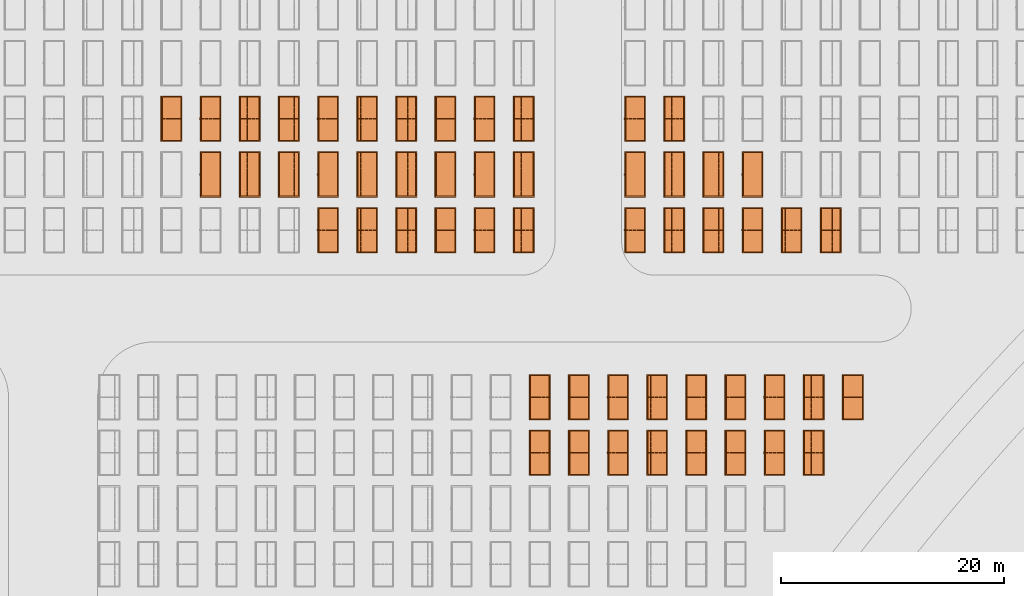
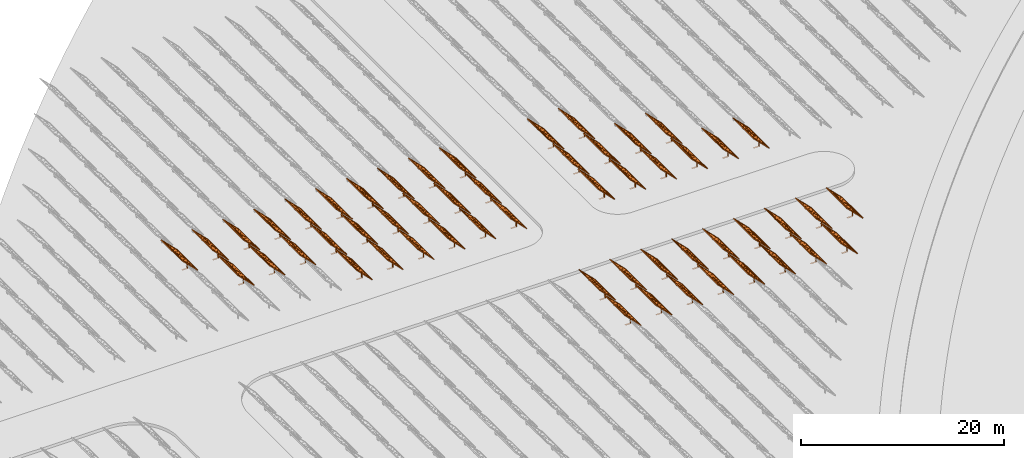
# One storey, part 34 of 39: 54 proxies.
"""IFC2X3 building model written with IfcOpenShell, lengths in millimetres."""

from ifc_helpers import new_model, entity, si_unit, converted_unit, derived_unit, direction, frame, frame_2d, origin, origin_2d_with_axis, place, context, subcontext, project, spatial, polyline, rectangle, outline, extrude, source, transform, mapped, material, material_list, element, save


model = new_model("IFC2X3")

# Units and contexts
model_context = context("Model", 3, precision=1e-06, world=origin(), true_north=direction((2.0, 6.12303176911189e-17, 1.0)))
context_of_model = context(None, 3, precision=1e-06, world=origin(), true_north=direction((2.0, 6.12303176911189e-17, 1.0)))
body_context = subcontext(model_context, "Body", "Model", "MODEL_VIEW")
ifc_project = project(units=[si_unit("LENGTHUNIT", "METRE", prefix="MILLI"), si_unit("AREAUNIT", "SQUARE_METRE", prefix="MILLI"), si_unit("VOLUMEUNIT", "CUBIC_METRE", prefix="MILLI"), converted_unit("PLANEANGLEUNIT", "DEGREE", entity("IfcRatioMeasure", 0.0174532925199433), si_unit("PLANEANGLEUNIT", "RADIAN"), dimensions=[0, 0, 0, 0, 0, 0, 0]), si_unit("MASSUNIT", "GRAM", prefix="KILO"), si_unit("TIMEUNIT", "SECOND"), si_unit("THERMODYNAMICTEMPERATUREUNIT", "KELVIN"), derived_unit("THERMALTRANSMITTANCEUNIT", [(si_unit("MASSUNIT", "GRAM", prefix="KILO"), 1), (si_unit("THERMODYNAMICTEMPERATUREUNIT", "KELVIN"), -1), (si_unit("TIMEUNIT", "SECOND"), -3)]), derived_unit("VOLUMETRICFLOWRATEUNIT", [(si_unit("LENGTHUNIT", "METRE"), 3), (si_unit("TIMEUNIT", "SECOND"), -1)])], contexts=[model_context, context_of_model])

# Site, building, storey
site_placement = place(None, origin())
site = spatial("IfcSite", under=ifc_project, at=site_placement, CompositionType="ELEMENT")
building_placement = place(site_placement, origin())
building = spatial("IfcBuilding", under=site, at=building_placement, CompositionType="ELEMENT")
storey_placement = place(building_placement, frame((0.0, 0.0, 4000.0)))
storey = spatial("IfcBuildingStorey", under=building, at=storey_placement, Name="Level 2", CompositionType="ELEMENT", Elevation=4000.0)

# Proxies
ifc_material_1 = material(Name="Stand-Steel")
ifc_material_2 = material(Name="Aluminium")
ifc_material_3 = material(Name="Glass")
ifc_material_list_1 = material_list([ifc_material_1, ifc_material_2, ifc_material_3])
shared_shape = source(origin(), body_context, "Body", "SweptSolid", [
    extrude(outline(polyline([(-629.526235435404, -220.0), (329.763117717702, -220.0), (329.763117717703, 410.0), (299.763117717703, 410.0), (299.763117717702, -190.0), (-629.526235435404, -190.0), (-629.526235435404, -220.0)])), frame((-190.00003127179, -100.0, 299.763117717707), z_axis=(0.0, 1.0, 0.0), x_axis=(0.0, 0.0, -1.0)), (0.0, 0.0, 1.0), 200.0),
    extrude(rectangle(XDim=20.0000000000001, YDim=200.0, at=frame_2d((0.0, -7.105427357601e-14), x_axis=(0.0, 1.0))), frame((-7.07109908365613, 0.0, 922.21828534124), z_axis=(-0.70710678118654, 0.0, 0.707106781186555), x_axis=(0.0, 1.0, 0.0)), (0.0, 0.0, 1.0), 2600.0),
    extrude(rectangle(XDim=24.9999999999997, YDim=24.9999999999999, at=frame_2d((2.87769807982841e-13, -9.50350909079134e-14), x_axis=(1.0, 0.0))), frame((-1449.56292018118, -1950.0, 2449.57494522722), z_axis=(0.0, 1.0, 0.0), x_axis=(-0.707106781186548, 0.0, -0.707106781186548)), (0.0, 0.0, 1.0), 3900.0),
    extrude(rectangle(XDim=24.9999999999999, YDim=25.0000000000001, at=origin_2d_with_axis()), frame((-1096.0095295879, -1950.0, 2096.02155463395), z_axis=(0.0, 1.0, 0.0), x_axis=(-0.707106781186542, 0.0, -0.707106781186553)), (0.0, 0.0, 1.0), 3900.0),
    extrude(rectangle(XDim=24.9999999999999, YDim=25.0000000000001, at=origin_2d_with_axis()), frame((-742.456138994631, -1950.0, 1742.46816404067), z_axis=(0.0, 1.0, 0.0), x_axis=(-0.707106781186542, 0.0, -0.707106781186553)), (0.0, 0.0, 1.0), 3900.0),
    extrude(rectangle(XDim=25.0, YDim=24.9999999999997, at=frame_2d((-7.19424519957101e-14, 1.19904086659517e-13), x_axis=(1.0, 0.0))), frame((-388.902748401358, -1950.0, 1388.9147734474), z_axis=(0.0, 1.0, 0.0), x_axis=(-0.707106781186545, 0.0, -0.70710678118655)), (0.0, 0.0, 1.0), 3900.0),
    extrude(rectangle(XDim=25.0000000000002, YDim=25.0, at=frame_2d((1.35891298214119e-13, 6.21724893790088e-15), x_axis=(0.0, 1.0))), frame((-35.3553703311048, 1500.0, 1035.35537033109), z_axis=(-0.707106781186544, 0.0, 0.707106781186551), x_axis=(0.0, 1.0, 0.0)), (0.0, 0.0, 1.0), 2440.0),
    extrude(rectangle(XDim=25.0000000000002, YDim=25.0, at=frame_2d((0.0, 1.77635683940025e-15), x_axis=(0.0, 1.0))), frame((-35.3553703311059, 1000.0, 1035.35537033109), z_axis=(-0.707106781186546, 0.0, 0.707106781186549), x_axis=(0.0, 1.0, 0.0)), (0.0, 0.0, 1.0), 2440.0),
    extrude(rectangle(XDim=25.0000000000002, YDim=25.0, at=frame_2d((0.0, 8.43769498715119e-14), x_axis=(0.0, 1.0))), frame((-26.5165355662756, 0.0, 1044.19420509593), z_axis=(-0.707106781186546, 0.0, 0.707106781186549), x_axis=(0.0, -1.0, 0.0)), (0.0, 0.0, 1.0), 2440.0),
    extrude(rectangle(XDim=25.0000000000002, YDim=25.0, at=frame_2d((0.0, 8.88178419700125e-16), x_axis=(0.0, 1.0))), frame((-35.3553703311065, 500.0, 1035.35537033109), z_axis=(-0.707106781186546, 0.0, 0.707106781186549), x_axis=(0.0, 1.0, 0.0)), (0.0, 0.0, 1.0), 2440.0),
    extrude(rectangle(XDim=25.0000000000002, YDim=25.0, at=frame_2d((0.0, 8.88178419700125e-16), x_axis=(0.0, 1.0))), frame((-35.3553703311086, -500.0, 1035.35537033109), z_axis=(-0.707106781186546, 0.0, 0.707106781186549), x_axis=(0.0, 1.0, 0.0)), (0.0, 0.0, 1.0), 2440.0),
    extrude(rectangle(XDim=25.0000000000002, YDim=25.0, at=frame_2d((0.0, 8.88178419700125e-16), x_axis=(0.0, 1.0))), frame((-35.3553703311095, -1000.0, 1035.35537033109), z_axis=(-0.707106781186546, 0.0, 0.707106781186549), x_axis=(0.0, 1.0, 0.0)), (0.0, 0.0, 1.0), 2440.0),
    extrude(rectangle(XDim=25.0000000000002, YDim=25.0, at=frame_2d((1.35891298214119e-13, 1.77635683940025e-15), x_axis=(0.0, 1.0))), frame((-35.3553703311107, -1500.0, 1035.35537033109), z_axis=(-0.707106781186546, 0.0, 0.707106781186549), x_axis=(0.0, 1.0, 0.0)), (0.0, 0.0, 1.0), 2440.0),
    extrude(rectangle(XDim=2400.0, YDim=11.9999999999994, at=frame_2d((-1.13686837721616e-13, 2.02948768901479e-13), x_axis=(1.0, 0.0))), frame((-883.883507754966, -1950.0, 1883.88350775495), z_axis=(0.0, 1.0, 0.0), x_axis=(0.707106781186546, 0.0, -0.707106781186549)), (0.0, 0.0, 1.0), 3900.0),
    extrude(outline(polyline([(-2050.0, -1300.0), (2050.0, -1300.0), (2050.0, 1300.0), (-2050.0, 1300.0), (-2050.0, -1300.0)]), holes=[polyline([(1950.0, -1200.0), (-1950.0, -1200.0), (-1950.0, 1200.0), (1950.0, 1200.0), (1950.0, -1200.0)])]), frame((-919.238846814293, 0.0, 1848.52816869563), z_axis=(0.707106781186554, 0.0, 0.707106781186541), x_axis=(0.0, 1.0, 0.0)), (0.0, 0.0, 1.0), 99.9999999999898),
])
proxy_1_placement = place(storey_placement, frame((-109235.224594532, 625144.680552408, 30.0)))
element("IfcBuildingElementProxy", 1, at=proxy_1_placement, inside=storey, material=ifc_material_list_1, Name="Solar Panel_4000X2500:Solar Panel_4000X2500", ObjectType="Solar Panel_4000X2500", CompositionType="ELEMENT", context=body_context, shape_type="MappedRepresentation", body=[
    mapped(shared_shape, transform((0.0, 0.0, 0.0), scale=1.0)),
])
ifc_material_list_2 = material_list([ifc_material_1, ifc_material_2, ifc_material_3])
proxy_2_placement = place(storey_placement, frame((-109235.224594532, 630144.680552408, 30.0)))
element("IfcBuildingElementProxy", 2, at=proxy_2_placement, inside=storey, material=ifc_material_list_2, Name="Solar Panel_4000X2500:Solar Panel_4000X2500", ObjectType="Solar Panel_4000X2500", CompositionType="ELEMENT", context=body_context, shape_type="MappedRepresentation", body=[
    mapped(shared_shape, transform((0.0, 0.0, 0.0), scale=1.0)),
])
ifc_material_list_3 = material_list([ifc_material_1, ifc_material_2, ifc_material_3])
proxy_3_placement = place(storey_placement, frame((-105720.214222803, 625144.680552408, 30.0)))
element("IfcBuildingElementProxy", 3, at=proxy_3_placement, inside=storey, material=ifc_material_list_3, Name="Solar Panel_4000X2500:Solar Panel_4000X2500", ObjectType="Solar Panel_4000X2500", CompositionType="ELEMENT", context=body_context, shape_type="MappedRepresentation", body=[
    mapped(shared_shape, transform((0.0, 0.0, 0.0), scale=1.0)),
])
ifc_material_list_4 = material_list([ifc_material_1, ifc_material_2, ifc_material_3])
proxy_4_placement = place(storey_placement, frame((-105720.214222803, 630144.680552408, 30.0)))
element("IfcBuildingElementProxy", 4, at=proxy_4_placement, inside=storey, material=ifc_material_list_4, Name="Solar Panel_4000X2500:Solar Panel_4000X2500", ObjectType="Solar Panel_4000X2500", CompositionType="ELEMENT", context=body_context, shape_type="MappedRepresentation", body=[
    mapped(shared_shape, transform((0.0, 0.0, 0.0), scale=1.0)),
])
ifc_material_list_5 = material_list([ifc_material_1, ifc_material_2, ifc_material_3])
proxy_5_placement = place(storey_placement, frame((-102205.203851073, 625144.680552408, 30.0)))
element("IfcBuildingElementProxy", 5, at=proxy_5_placement, inside=storey, material=ifc_material_list_5, Name="Solar Panel_4000X2500:Solar Panel_4000X2500", ObjectType="Solar Panel_4000X2500", CompositionType="ELEMENT", context=body_context, shape_type="MappedRepresentation", body=[
    mapped(shared_shape, transform((0.0, 0.0, 0.0), scale=1.0)),
])
ifc_material_list_6 = material_list([ifc_material_1, ifc_material_2, ifc_material_3])
proxy_6_placement = place(storey_placement, frame((-102205.203851073, 630144.680552408, 30.0)))
element("IfcBuildingElementProxy", 6, at=proxy_6_placement, inside=storey, material=ifc_material_list_6, Name="Solar Panel_4000X2500:Solar Panel_4000X2500", ObjectType="Solar Panel_4000X2500", CompositionType="ELEMENT", context=body_context, shape_type="MappedRepresentation", body=[
    mapped(shared_shape, transform((0.0, 0.0, 0.0), scale=1.0)),
])
ifc_material_list_7 = material_list([ifc_material_1, ifc_material_2, ifc_material_3])
proxy_7_placement = place(storey_placement, frame((-98690.193479343, 625144.680552408, 30.0)))
element("IfcBuildingElementProxy", 7, at=proxy_7_placement, inside=storey, material=ifc_material_list_7, Name="Solar Panel_4000X2500:Solar Panel_4000X2500", ObjectType="Solar Panel_4000X2500", CompositionType="ELEMENT", context=body_context, shape_type="MappedRepresentation", body=[
    mapped(shared_shape, transform((0.0, 0.0, 0.0), scale=1.0)),
])
ifc_material_list_8 = material_list([ifc_material_1, ifc_material_2, ifc_material_3])
proxy_8_placement = place(storey_placement, frame((-98690.193479343, 630144.680552408, 30.0)))
element("IfcBuildingElementProxy", 8, at=proxy_8_placement, inside=storey, material=ifc_material_list_8, Name="Solar Panel_4000X2500:Solar Panel_4000X2500", ObjectType="Solar Panel_4000X2500", CompositionType="ELEMENT", context=body_context, shape_type="MappedRepresentation", body=[
    mapped(shared_shape, transform((0.0, 0.0, 0.0), scale=1.0)),
])
ifc_material_list_9 = material_list([ifc_material_1, ifc_material_2, ifc_material_3])
proxy_9_placement = place(storey_placement, frame((-95175.1831076132, 625144.680552408, 30.0)))
element("IfcBuildingElementProxy", 9, at=proxy_9_placement, inside=storey, material=ifc_material_list_9, Name="Solar Panel_4000X2500:Solar Panel_4000X2500", ObjectType="Solar Panel_4000X2500", CompositionType="ELEMENT", context=body_context, shape_type="MappedRepresentation", body=[
    mapped(shared_shape, transform((0.0, 0.0, 0.0), scale=1.0)),
])
ifc_material_list_10 = material_list([ifc_material_1, ifc_material_2, ifc_material_3])
proxy_10_placement = place(storey_placement, frame((-95175.1831076132, 630144.680552408, 30.0)))
element("IfcBuildingElementProxy", 10, at=proxy_10_placement, inside=storey, material=ifc_material_list_10, Name="Solar Panel_4000X2500:Solar Panel_4000X2500", ObjectType="Solar Panel_4000X2500", CompositionType="ELEMENT", context=body_context, shape_type="MappedRepresentation", body=[
    mapped(shared_shape, transform((0.0, 0.0, 0.0), scale=1.0)),
])
ifc_material_list_11 = material_list([ifc_material_1, ifc_material_2, ifc_material_3])
proxy_11_placement = place(storey_placement, frame((-91660.1727358834, 625144.680552408, 30.0)))
element("IfcBuildingElementProxy", 11, at=proxy_11_placement, inside=storey, material=ifc_material_list_11, Name="Solar Panel_4000X2500:Solar Panel_4000X2500", ObjectType="Solar Panel_4000X2500", CompositionType="ELEMENT", context=body_context, shape_type="MappedRepresentation", body=[
    mapped(shared_shape, transform((0.0, 0.0, 0.0), scale=1.0)),
])
ifc_material_list_12 = material_list([ifc_material_1, ifc_material_2, ifc_material_3])
proxy_12_placement = place(storey_placement, frame((-91660.1727358834, 630144.680552408, 30.0)))
element("IfcBuildingElementProxy", 12, at=proxy_12_placement, inside=storey, material=ifc_material_list_12, Name="Solar Panel_4000X2500:Solar Panel_4000X2500", ObjectType="Solar Panel_4000X2500", CompositionType="ELEMENT", context=body_context, shape_type="MappedRepresentation", body=[
    mapped(shared_shape, transform((0.0, 0.0, 0.0), scale=1.0)),
])
ifc_material_list_13 = material_list([ifc_material_1, ifc_material_2, ifc_material_3])
proxy_13_placement = place(storey_placement, frame((-88145.1623641536, 625144.680552408, 30.0)))
element("IfcBuildingElementProxy", 13, at=proxy_13_placement, inside=storey, material=ifc_material_list_13, Name="Solar Panel_4000X2500:Solar Panel_4000X2500", ObjectType="Solar Panel_4000X2500", CompositionType="ELEMENT", context=body_context, shape_type="MappedRepresentation", body=[
    mapped(shared_shape, transform((0.0, 0.0, 0.0), scale=1.0)),
])
ifc_material_list_14 = material_list([ifc_material_1, ifc_material_2, ifc_material_3])
proxy_14_placement = place(storey_placement, frame((-88145.1623641536, 630144.680552408, 30.0)))
element("IfcBuildingElementProxy", 14, at=proxy_14_placement, inside=storey, material=ifc_material_list_14, Name="Solar Panel_4000X2500:Solar Panel_4000X2500", ObjectType="Solar Panel_4000X2500", CompositionType="ELEMENT", context=body_context, shape_type="MappedRepresentation", body=[
    mapped(shared_shape, transform((0.0, 0.0, 0.0), scale=1.0)),
])
ifc_material_list_15 = material_list([ifc_material_1, ifc_material_2, ifc_material_3])
proxy_15_placement = place(storey_placement, frame((-84630.1519924238, 625144.680552408, 30.0)))
element("IfcBuildingElementProxy", 15, at=proxy_15_placement, inside=storey, material=ifc_material_list_15, Name="Solar Panel_4000X2500:Solar Panel_4000X2500", ObjectType="Solar Panel_4000X2500", CompositionType="ELEMENT", context=body_context, shape_type="MappedRepresentation", body=[
    mapped(shared_shape, transform((0.0, 0.0, 0.0), scale=1.0)),
])
ifc_material_list_16 = material_list([ifc_material_1, ifc_material_2, ifc_material_3])
proxy_16_placement = place(storey_placement, frame((-84630.1519924238, 630144.680552408, 30.0)))
element("IfcBuildingElementProxy", 16, at=proxy_16_placement, inside=storey, material=ifc_material_list_16, Name="Solar Panel_4000X2500:Solar Panel_4000X2500", ObjectType="Solar Panel_4000X2500", CompositionType="ELEMENT", context=body_context, shape_type="MappedRepresentation", body=[
    mapped(shared_shape, transform((0.0, 0.0, 0.0), scale=1.0)),
])
ifc_material_list_17 = material_list([ifc_material_1, ifc_material_2, ifc_material_3])
proxy_17_placement = place(storey_placement, frame((-81115.141620694, 630144.680552408, 30.0)))
element("IfcBuildingElementProxy", 17, at=proxy_17_placement, inside=storey, material=ifc_material_list_17, Name="Solar Panel_4000X2500:Solar Panel_4000X2500", ObjectType="Solar Panel_4000X2500", CompositionType="ELEMENT", context=body_context, shape_type="MappedRepresentation", body=[
    mapped(shared_shape, transform((0.0, 0.0, 0.0), scale=1.0)),
])
ifc_material_list_18 = material_list([ifc_material_1, ifc_material_2, ifc_material_3])
proxy_18_placement = place(storey_placement, frame((-128250.276453181, 645144.680552408, 30.0)))
element("IfcBuildingElementProxy", 18, at=proxy_18_placement, inside=storey, material=ifc_material_list_18, Name="Solar Panel_4000X2500:Solar Panel_4000X2500", ObjectType="Solar Panel_4000X2500", CompositionType="ELEMENT", context=body_context, shape_type="MappedRepresentation", body=[
    mapped(shared_shape, transform((0.0, 0.0, 0.0), scale=1.0)),
])
ifc_material_list_19 = material_list([ifc_material_1, ifc_material_2, ifc_material_3])
proxy_19_placement = place(storey_placement, frame((-124735.266081451, 645144.680552408, 30.0)))
element("IfcBuildingElementProxy", 19, at=proxy_19_placement, inside=storey, material=ifc_material_list_19, Name="Solar Panel_4000X2500:Solar Panel_4000X2500", ObjectType="Solar Panel_4000X2500", CompositionType="ELEMENT", context=body_context, shape_type="MappedRepresentation", body=[
    mapped(shared_shape, transform((0.0, 0.0, 0.0), scale=1.0)),
])
ifc_material_list_20 = material_list([ifc_material_1, ifc_material_2, ifc_material_3])
proxy_20_placement = place(storey_placement, frame((-121220.255709722, 645144.680552408, 30.0)))
element("IfcBuildingElementProxy", 20, at=proxy_20_placement, inside=storey, material=ifc_material_list_20, Name="Solar Panel_4000X2500:Solar Panel_4000X2500", ObjectType="Solar Panel_4000X2500", CompositionType="ELEMENT", context=body_context, shape_type="MappedRepresentation", body=[
    mapped(shared_shape, transform((0.0, 0.0, 0.0), scale=1.0)),
])
ifc_material_list_21 = material_list([ifc_material_1, ifc_material_2, ifc_material_3])
proxy_21_placement = place(storey_placement, frame((-117705.245337992, 645144.680552408, 30.0)))
element("IfcBuildingElementProxy", 21, at=proxy_21_placement, inside=storey, material=ifc_material_list_21, Name="Solar Panel_4000X2500:Solar Panel_4000X2500", ObjectType="Solar Panel_4000X2500", CompositionType="ELEMENT", context=body_context, shape_type="MappedRepresentation", body=[
    mapped(shared_shape, transform((0.0, 0.0, 0.0), scale=1.0)),
])
ifc_material_list_22 = material_list([ifc_material_1, ifc_material_2, ifc_material_3])
proxy_22_placement = place(storey_placement, frame((-100675.224594532, 645144.680552408, 30.0)))
element("IfcBuildingElementProxy", 22, at=proxy_22_placement, inside=storey, material=ifc_material_list_22, Name="Solar Panel_4000X2500:Solar Panel_4000X2500", ObjectType="Solar Panel_4000X2500", CompositionType="ELEMENT", context=body_context, shape_type="MappedRepresentation", body=[
    mapped(shared_shape, transform((0.0, 0.0, 0.0), scale=1.0)),
])
ifc_material_list_23 = material_list([ifc_material_1, ifc_material_2, ifc_material_3])
proxy_23_placement = place(storey_placement, frame((-97160.2142228024, 645144.680552408, 30.0)))
element("IfcBuildingElementProxy", 23, at=proxy_23_placement, inside=storey, material=ifc_material_list_23, Name="Solar Panel_4000X2500:Solar Panel_4000X2500", ObjectType="Solar Panel_4000X2500", CompositionType="ELEMENT", context=body_context, shape_type="MappedRepresentation", body=[
    mapped(shared_shape, transform((0.0, 0.0, 0.0), scale=1.0)),
])
ifc_material_list_24 = material_list([ifc_material_1, ifc_material_2, ifc_material_3])
proxy_24_placement = place(storey_placement, frame((-93645.2038510726, 645144.680552408, 30.0)))
element("IfcBuildingElementProxy", 24, at=proxy_24_placement, inside=storey, material=ifc_material_list_24, Name="Solar Panel_4000X2500:Solar Panel_4000X2500", ObjectType="Solar Panel_4000X2500", CompositionType="ELEMENT", context=body_context, shape_type="MappedRepresentation", body=[
    mapped(shared_shape, transform((0.0, 0.0, 0.0), scale=1.0)),
])
ifc_material_list_25 = material_list([ifc_material_1, ifc_material_2, ifc_material_3])
proxy_25_placement = place(storey_placement, frame((-90130.1934793428, 645144.680552408, 30.0)))
element("IfcBuildingElementProxy", 25, at=proxy_25_placement, inside=storey, material=ifc_material_list_25, Name="Solar Panel_4000X2500:Solar Panel_4000X2500", ObjectType="Solar Panel_4000X2500", CompositionType="ELEMENT", context=body_context, shape_type="MappedRepresentation", body=[
    mapped(shared_shape, transform((0.0, 0.0, 0.0), scale=1.0)),
])
ifc_material_list_26 = material_list([ifc_material_1, ifc_material_2, ifc_material_3])
proxy_26_placement = place(storey_placement, frame((-86615.183107613, 645144.680552408, 30.0)))
element("IfcBuildingElementProxy", 26, at=proxy_26_placement, inside=storey, material=ifc_material_list_26, Name="Solar Panel_4000X2500:Solar Panel_4000X2500", ObjectType="Solar Panel_4000X2500", CompositionType="ELEMENT", context=body_context, shape_type="MappedRepresentation", body=[
    mapped(shared_shape, transform((0.0, 0.0, 0.0), scale=1.0)),
])
ifc_material_list_27 = material_list([ifc_material_1, ifc_material_2, ifc_material_3])
proxy_27_placement = place(storey_placement, frame((-83100.1727358832, 645144.680552408, 30.0)))
element("IfcBuildingElementProxy", 27, at=proxy_27_placement, inside=storey, material=ifc_material_list_27, Name="Solar Panel_4000X2500:Solar Panel_4000X2500", ObjectType="Solar Panel_4000X2500", CompositionType="ELEMENT", context=body_context, shape_type="MappedRepresentation", body=[
    mapped(shared_shape, transform((0.0, 0.0, 0.0), scale=1.0)),
])
ifc_material_list_28 = material_list([ifc_material_1, ifc_material_2, ifc_material_3])
proxy_28_placement = place(storey_placement, frame((-138795.307568371, 650144.680552408, 30.0)))
element("IfcBuildingElementProxy", 28, at=proxy_28_placement, inside=storey, material=ifc_material_list_28, Name="Solar Panel_4000X2500:Solar Panel_4000X2500", ObjectType="Solar Panel_4000X2500", CompositionType="ELEMENT", context=body_context, shape_type="MappedRepresentation", body=[
    mapped(shared_shape, transform((0.0, 0.0, 0.0), scale=1.0)),
])
ifc_material_list_29 = material_list([ifc_material_1, ifc_material_2, ifc_material_3])
proxy_29_placement = place(storey_placement, frame((-135280.297196641, 650144.680552408, 30.0)))
element("IfcBuildingElementProxy", 29, at=proxy_29_placement, inside=storey, material=ifc_material_list_29, Name="Solar Panel_4000X2500:Solar Panel_4000X2500", ObjectType="Solar Panel_4000X2500", CompositionType="ELEMENT", context=body_context, shape_type="MappedRepresentation", body=[
    mapped(shared_shape, transform((0.0, 0.0, 0.0), scale=1.0)),
])
ifc_material_list_30 = material_list([ifc_material_1, ifc_material_2, ifc_material_3])
proxy_30_placement = place(storey_placement, frame((-131765.286824911, 650144.680552408, 30.0)))
element("IfcBuildingElementProxy", 30, at=proxy_30_placement, inside=storey, material=ifc_material_list_30, Name="Solar Panel_4000X2500:Solar Panel_4000X2500", ObjectType="Solar Panel_4000X2500", CompositionType="ELEMENT", context=body_context, shape_type="MappedRepresentation", body=[
    mapped(shared_shape, transform((0.0, 0.0, 0.0), scale=1.0)),
])
ifc_material_list_31 = material_list([ifc_material_1, ifc_material_2, ifc_material_3])
proxy_31_placement = place(storey_placement, frame((-128250.276453181, 650144.680552408, 30.0)))
element("IfcBuildingElementProxy", 31, at=proxy_31_placement, inside=storey, material=ifc_material_list_31, Name="Solar Panel_4000X2500:Solar Panel_4000X2500", ObjectType="Solar Panel_4000X2500", CompositionType="ELEMENT", context=body_context, shape_type="MappedRepresentation", body=[
    mapped(shared_shape, transform((0.0, 0.0, 0.0), scale=1.0)),
])
ifc_material_list_32 = material_list([ifc_material_1, ifc_material_2, ifc_material_3])
proxy_32_placement = place(storey_placement, frame((-124735.266081451, 650144.680552408, 30.0)))
element("IfcBuildingElementProxy", 32, at=proxy_32_placement, inside=storey, material=ifc_material_list_32, Name="Solar Panel_4000X2500:Solar Panel_4000X2500", ObjectType="Solar Panel_4000X2500", CompositionType="ELEMENT", context=body_context, shape_type="MappedRepresentation", body=[
    mapped(shared_shape, transform((0.0, 0.0, 0.0), scale=1.0)),
])
ifc_material_list_33 = material_list([ifc_material_1, ifc_material_2, ifc_material_3])
proxy_33_placement = place(storey_placement, frame((-121220.255709722, 650144.680552408, 30.0)))
element("IfcBuildingElementProxy", 33, at=proxy_33_placement, inside=storey, material=ifc_material_list_33, Name="Solar Panel_4000X2500:Solar Panel_4000X2500", ObjectType="Solar Panel_4000X2500", CompositionType="ELEMENT", context=body_context, shape_type="MappedRepresentation", body=[
    mapped(shared_shape, transform((0.0, 0.0, 0.0), scale=1.0)),
])
ifc_material_list_34 = material_list([ifc_material_1, ifc_material_2, ifc_material_3])
proxy_34_placement = place(storey_placement, frame((-117705.245337992, 650144.680552408, 30.0)))
element("IfcBuildingElementProxy", 34, at=proxy_34_placement, inside=storey, material=ifc_material_list_34, Name="Solar Panel_4000X2500:Solar Panel_4000X2500", ObjectType="Solar Panel_4000X2500", CompositionType="ELEMENT", context=body_context, shape_type="MappedRepresentation", body=[
    mapped(shared_shape, transform((0.0, 0.0, 0.0), scale=1.0)),
])
ifc_material_list_35 = material_list([ifc_material_1, ifc_material_2, ifc_material_3])
proxy_35_placement = place(storey_placement, frame((-100675.224594532, 650144.680552408, 30.0)))
element("IfcBuildingElementProxy", 35, at=proxy_35_placement, inside=storey, material=ifc_material_list_35, Name="Solar Panel_4000X2500:Solar Panel_4000X2500", ObjectType="Solar Panel_4000X2500", CompositionType="ELEMENT", context=body_context, shape_type="MappedRepresentation", body=[
    mapped(shared_shape, transform((0.0, 0.0, 0.0), scale=1.0)),
])
ifc_material_list_36 = material_list([ifc_material_1, ifc_material_2, ifc_material_3])
proxy_36_placement = place(storey_placement, frame((-97160.2142228024, 650144.680552408, 30.0)))
element("IfcBuildingElementProxy", 36, at=proxy_36_placement, inside=storey, material=ifc_material_list_36, Name="Solar Panel_4000X2500:Solar Panel_4000X2500", ObjectType="Solar Panel_4000X2500", CompositionType="ELEMENT", context=body_context, shape_type="MappedRepresentation", body=[
    mapped(shared_shape, transform((0.0, 0.0, 0.0), scale=1.0)),
])
ifc_material_list_37 = material_list([ifc_material_1, ifc_material_2, ifc_material_3])
proxy_37_placement = place(storey_placement, frame((-93645.2038510726, 650144.680552408, 30.0)))
element("IfcBuildingElementProxy", 37, at=proxy_37_placement, inside=storey, material=ifc_material_list_37, Name="Solar Panel_4000X2500:Solar Panel_4000X2500", ObjectType="Solar Panel_4000X2500", CompositionType="ELEMENT", context=body_context, shape_type="MappedRepresentation", body=[
    mapped(shared_shape, transform((0.0, 0.0, 0.0), scale=1.0)),
])
ifc_material_list_38 = material_list([ifc_material_1, ifc_material_2, ifc_material_3])
proxy_38_placement = place(storey_placement, frame((-90130.1934793428, 650144.680552408, 30.0)))
element("IfcBuildingElementProxy", 38, at=proxy_38_placement, inside=storey, material=ifc_material_list_38, Name="Solar Panel_4000X2500:Solar Panel_4000X2500", ObjectType="Solar Panel_4000X2500", CompositionType="ELEMENT", context=body_context, shape_type="MappedRepresentation", body=[
    mapped(shared_shape, transform((0.0, 0.0, 0.0), scale=1.0)),
])
ifc_material_list_39 = material_list([ifc_material_1, ifc_material_2, ifc_material_3])
proxy_39_placement = place(storey_placement, frame((-142310.3179401, 655144.680552408, 30.0)))
element("IfcBuildingElementProxy", 39, at=proxy_39_placement, inside=storey, material=ifc_material_list_39, Name="Solar Panel_4000X2500:Solar Panel_4000X2500", ObjectType="Solar Panel_4000X2500", CompositionType="ELEMENT", context=body_context, shape_type="MappedRepresentation", body=[
    mapped(shared_shape, transform((0.0, 0.0, 0.0), scale=1.0)),
])
ifc_material_list_40 = material_list([ifc_material_1, ifc_material_2, ifc_material_3])
proxy_40_placement = place(storey_placement, frame((-138795.307568371, 655144.680552408, 30.0)))
element("IfcBuildingElementProxy", 40, at=proxy_40_placement, inside=storey, material=ifc_material_list_40, Name="Solar Panel_4000X2500:Solar Panel_4000X2500", ObjectType="Solar Panel_4000X2500", CompositionType="ELEMENT", context=body_context, shape_type="MappedRepresentation", body=[
    mapped(shared_shape, transform((0.0, 0.0, 0.0), scale=1.0)),
])
ifc_material_list_41 = material_list([ifc_material_1, ifc_material_2, ifc_material_3])
proxy_41_placement = place(storey_placement, frame((-135280.297196641, 655144.680552408, 30.0)))
element("IfcBuildingElementProxy", 41, at=proxy_41_placement, inside=storey, material=ifc_material_list_41, Name="Solar Panel_4000X2500:Solar Panel_4000X2500", ObjectType="Solar Panel_4000X2500", CompositionType="ELEMENT", context=body_context, shape_type="MappedRepresentation", body=[
    mapped(shared_shape, transform((0.0, 0.0, 0.0), scale=1.0)),
])
ifc_material_list_42 = material_list([ifc_material_1, ifc_material_2, ifc_material_3])
proxy_42_placement = place(storey_placement, frame((-131765.286824911, 655144.680552408, 30.0)))
element("IfcBuildingElementProxy", 42, at=proxy_42_placement, inside=storey, material=ifc_material_list_42, Name="Solar Panel_4000X2500:Solar Panel_4000X2500", ObjectType="Solar Panel_4000X2500", CompositionType="ELEMENT", context=body_context, shape_type="MappedRepresentation", body=[
    mapped(shared_shape, transform((0.0, 0.0, 0.0), scale=1.0)),
])
ifc_material_list_43 = material_list([ifc_material_1, ifc_material_2, ifc_material_3])
proxy_43_placement = place(storey_placement, frame((-128250.276453181, 655144.680552408, 30.0)))
element("IfcBuildingElementProxy", 43, at=proxy_43_placement, inside=storey, material=ifc_material_list_43, Name="Solar Panel_4000X2500:Solar Panel_4000X2500", ObjectType="Solar Panel_4000X2500", CompositionType="ELEMENT", context=body_context, shape_type="MappedRepresentation", body=[
    mapped(shared_shape, transform((0.0, 0.0, 0.0), scale=1.0)),
])
ifc_material_list_44 = material_list([ifc_material_1, ifc_material_2, ifc_material_3])
proxy_44_placement = place(storey_placement, frame((-124735.266081451, 655144.680552408, 30.0)))
element("IfcBuildingElementProxy", 44, at=proxy_44_placement, inside=storey, material=ifc_material_list_44, Name="Solar Panel_4000X2500:Solar Panel_4000X2500", ObjectType="Solar Panel_4000X2500", CompositionType="ELEMENT", context=body_context, shape_type="MappedRepresentation", body=[
    mapped(shared_shape, transform((0.0, 0.0, 0.0), scale=1.0)),
])
ifc_material_list_45 = material_list([ifc_material_1, ifc_material_2, ifc_material_3])
proxy_45_placement = place(storey_placement, frame((-121220.255709722, 655144.680552408, 30.0)))
element("IfcBuildingElementProxy", 45, at=proxy_45_placement, inside=storey, material=ifc_material_list_45, Name="Solar Panel_4000X2500:Solar Panel_4000X2500", ObjectType="Solar Panel_4000X2500", CompositionType="ELEMENT", context=body_context, shape_type="MappedRepresentation", body=[
    mapped(shared_shape, transform((0.0, 0.0, 0.0), scale=1.0)),
])
ifc_material_list_46 = material_list([ifc_material_1, ifc_material_2, ifc_material_3])
proxy_46_placement = place(storey_placement, frame((-117705.245337992, 655144.680552408, 30.0)))
element("IfcBuildingElementProxy", 46, at=proxy_46_placement, inside=storey, material=ifc_material_list_46, Name="Solar Panel_4000X2500:Solar Panel_4000X2500", ObjectType="Solar Panel_4000X2500", CompositionType="ELEMENT", context=body_context, shape_type="MappedRepresentation", body=[
    mapped(shared_shape, transform((0.0, 0.0, 0.0), scale=1.0)),
])
ifc_material_list_47 = material_list([ifc_material_1, ifc_material_2, ifc_material_3])
proxy_47_placement = place(storey_placement, frame((-100675.224594532, 655144.680552408, 30.0)))
element("IfcBuildingElementProxy", 47, at=proxy_47_placement, inside=storey, material=ifc_material_list_47, Name="Solar Panel_4000X2500:Solar Panel_4000X2500", ObjectType="Solar Panel_4000X2500", CompositionType="ELEMENT", context=body_context, shape_type="MappedRepresentation", body=[
    mapped(shared_shape, transform((0.0, 0.0, 0.0), scale=1.0)),
])
ifc_material_list_48 = material_list([ifc_material_1, ifc_material_2, ifc_material_3])
proxy_48_placement = place(storey_placement, frame((-97160.2142228024, 655144.680552408, 30.0)))
element("IfcBuildingElementProxy", 48, at=proxy_48_placement, inside=storey, material=ifc_material_list_48, Name="Solar Panel_4000X2500:Solar Panel_4000X2500", ObjectType="Solar Panel_4000X2500", CompositionType="ELEMENT", context=body_context, shape_type="MappedRepresentation", body=[
    mapped(shared_shape, transform((0.0, 0.0, 0.0), scale=1.0)),
])
ifc_material_list_49 = material_list([ifc_material_1, ifc_material_2, ifc_material_3])
proxy_49_placement = place(storey_placement, frame((-114190.234966262, 645144.680552408, 30.0)))
element("IfcBuildingElementProxy", 49, at=proxy_49_placement, inside=storey, material=ifc_material_list_49, Name="Solar Panel_4000X2500:Solar Panel_4000X2500", ObjectType="Solar Panel_4000X2500", CompositionType="ELEMENT", context=body_context, shape_type="MappedRepresentation", body=[
    mapped(shared_shape, transform((0.0, 0.0, 0.0), scale=1.0)),
])
ifc_material_list_50 = material_list([ifc_material_1, ifc_material_2, ifc_material_3])
proxy_50_placement = place(storey_placement, frame((-110675.224594532, 645144.680552408, 30.0)))
element("IfcBuildingElementProxy", 50, at=proxy_50_placement, inside=storey, material=ifc_material_list_50, Name="Solar Panel_4000X2500:Solar Panel_4000X2500", ObjectType="Solar Panel_4000X2500", CompositionType="ELEMENT", context=body_context, shape_type="MappedRepresentation", body=[
    mapped(shared_shape, transform((0.0, 0.0, 0.0), scale=1.0)),
])
ifc_material_list_51 = material_list([ifc_material_1, ifc_material_2, ifc_material_3])
proxy_51_placement = place(storey_placement, frame((-114190.234966262, 650144.680552408, 30.0)))
element("IfcBuildingElementProxy", 51, at=proxy_51_placement, inside=storey, material=ifc_material_list_51, Name="Solar Panel_4000X2500:Solar Panel_4000X2500", ObjectType="Solar Panel_4000X2500", CompositionType="ELEMENT", context=body_context, shape_type="MappedRepresentation", body=[
    mapped(shared_shape, transform((0.0, 0.0, 0.0), scale=1.0)),
])
ifc_material_list_52 = material_list([ifc_material_1, ifc_material_2, ifc_material_3])
proxy_52_placement = place(storey_placement, frame((-110675.224594532, 650144.680552408, 30.0)))
element("IfcBuildingElementProxy", 52, at=proxy_52_placement, inside=storey, material=ifc_material_list_52, Name="Solar Panel_4000X2500:Solar Panel_4000X2500", ObjectType="Solar Panel_4000X2500", CompositionType="ELEMENT", context=body_context, shape_type="MappedRepresentation", body=[
    mapped(shared_shape, transform((0.0, 0.0, 0.0), scale=1.0)),
])
ifc_material_list_53 = material_list([ifc_material_1, ifc_material_2, ifc_material_3])
proxy_53_placement = place(storey_placement, frame((-114190.234966262, 655144.680552408, 30.0)))
element("IfcBuildingElementProxy", 53, at=proxy_53_placement, inside=storey, material=ifc_material_list_53, Name="Solar Panel_4000X2500:Solar Panel_4000X2500", ObjectType="Solar Panel_4000X2500", CompositionType="ELEMENT", context=body_context, shape_type="MappedRepresentation", body=[
    mapped(shared_shape, transform((0.0, 0.0, 0.0), scale=1.0)),
])
ifc_material_list_54 = material_list([ifc_material_1, ifc_material_2, ifc_material_3])
proxy_54_placement = place(storey_placement, frame((-110675.224594532, 655144.680552408, 30.0)))
element("IfcBuildingElementProxy", 54, at=proxy_54_placement, inside=storey, material=ifc_material_list_54, Name="Solar Panel_4000X2500:Solar Panel_4000X2500", ObjectType="Solar Panel_4000X2500", CompositionType="ELEMENT", context=body_context, shape_type="MappedRepresentation", body=[
    mapped(shared_shape, transform((0.0, 0.0, 0.0), scale=1.0)),
])

save(model, "model.ifc")
